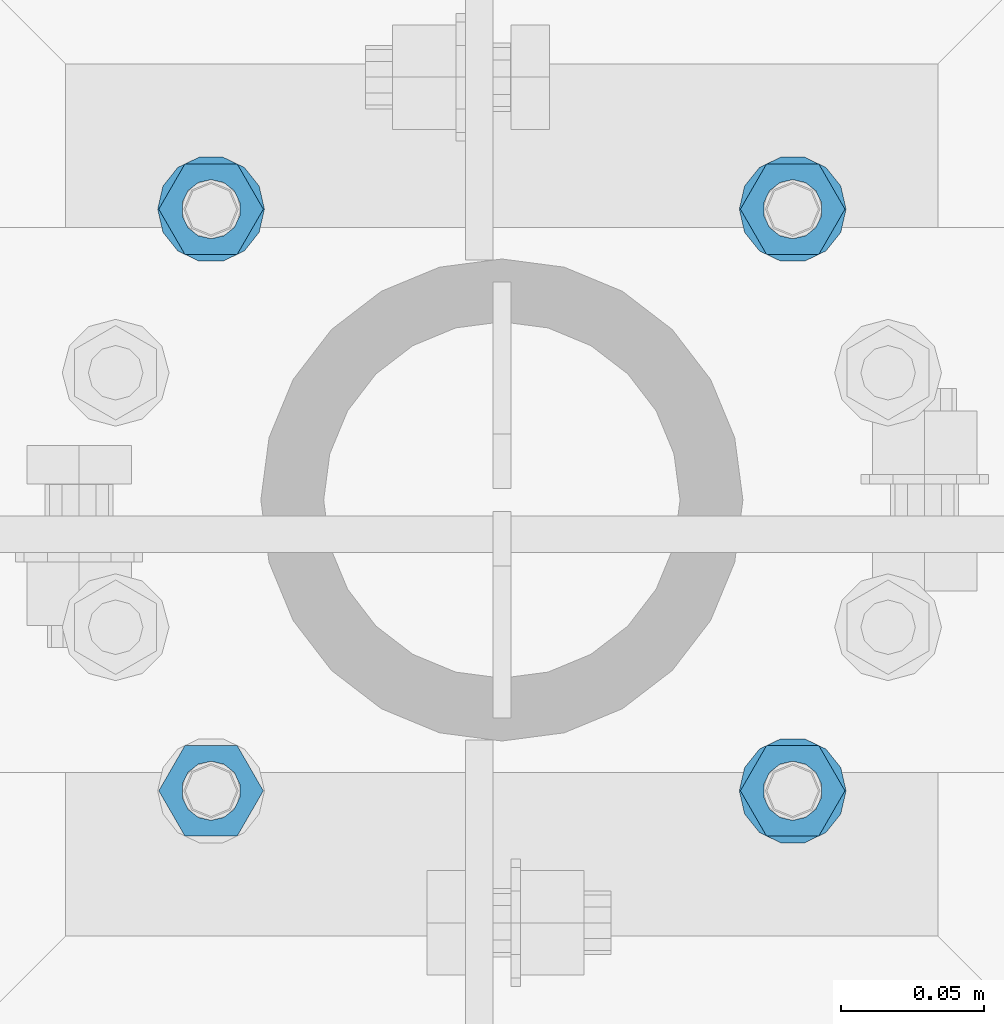
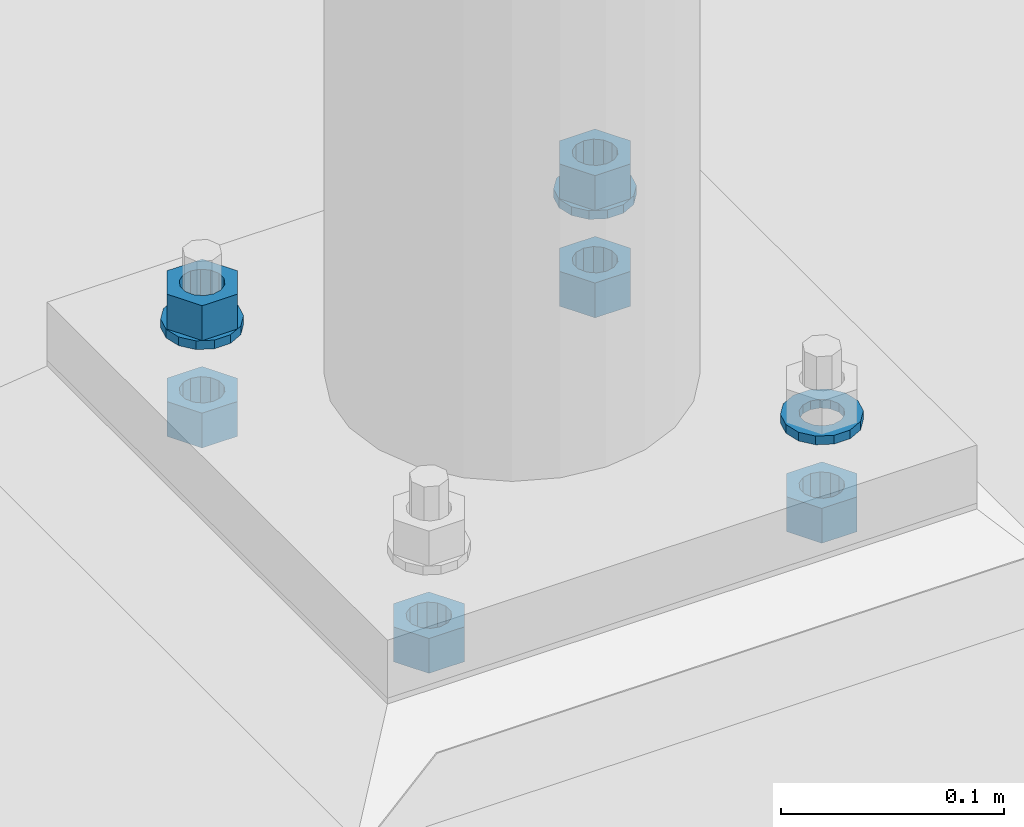
# One storey, part 572 of 975: 9 beams.
"""IFC2X3 building model written with IfcOpenShell, lengths in millimetres."""

from ifc_helpers import new_model, si_unit, frame, origin_with_axes, place, context, subcontext, project, spatial, faceted_brep, material, type_object, element, save


model = new_model("IFC2X3")

# Units and contexts
model_context = context("Model", 3, precision=1e-05, world=origin_with_axes())
body_context = subcontext(model_context, "Body", "Model", "MODEL_VIEW")
ifc_project = project(units=[si_unit("LENGTHUNIT", "METRE", prefix="MILLI"), si_unit("AREAUNIT", "SQUARE_METRE"), si_unit("VOLUMEUNIT", "CUBIC_METRE"), si_unit("MASSUNIT", "GRAM", prefix="KILO"), si_unit("TIMEUNIT", "SECOND"), si_unit("PLANEANGLEUNIT", "RADIAN"), si_unit("SOLIDANGLEUNIT", "STERADIAN"), si_unit("THERMODYNAMICTEMPERATUREUNIT", "DEGREE_CELSIUS"), si_unit("LUMINOUSINTENSITYUNIT", "LUMEN")], contexts=[model_context])

# Site, building, storey
site_placement = place(None, origin_with_axes())
site = spatial("IfcSite", under=ifc_project, at=site_placement, CompositionType="ELEMENT")
building_placement = place(site_placement, origin_with_axes())
building = spatial("IfcBuilding", under=site, at=building_placement, Name="Undefined", CompositionType="ELEMENT")
storey_placement = place(building_placement, origin_with_axes())
storey = spatial("IfcBuildingStorey", under=building, at=storey_placement, Name="Undefined", CompositionType="ELEMENT", Elevation=0.0)

# Beams
ifc_material = material(Name="STEEL/A36")
beam_type_1 = type_object("IfcBeamType", Name="3/4_WASHER", PredefinedType="NOTDEFINED")
beam_1_placement = place(storey_placement, frame((13588.9999984741, 5718.17500305176, -227.0125), z_axis=(0.0, 1.0, 0.0), x_axis=(0.0, 0.0, -1.0)))
element("IfcBeam", 1, at=beam_1_placement, inside=storey, type_object=beam_type_1, material=ifc_material, Name="WASHER", ObjectType="3/4_WASHER", context=body_context, shape_type="Brep", body=[
    faceted_brep([(0.0, -18.6499996185303, 0.0), (0.0, -16.8030690426876, -8.09193156902904), (4.76250000000073, -16.8030690426876, -8.09193156902904), (4.76250000000073, -18.6499996185303, 0.0), (0.0, -11.6280845668225, -14.5811568497838), (4.76250000000073, -11.6280845668225, -14.5811568497838), (0.0, -4.15001533340001, -18.1824051902857), (4.76250000000073, -4.15001533340001, -18.1824051902857), (0.0, 4.15001533340001, -18.1824051902857), (4.76250000000073, 4.15001533340001, -18.1824051902857), (0.0, 11.6280845668234, -14.5811568497838), (4.76250000000073, 11.6280845668234, -14.5811568497838), (0.0, 16.8030690426876, -8.09193156902904), (4.76250000000073, 16.8030690426876, -8.09193156902904), (0.0, 18.6499996185303, 0.0), (4.76250000000073, 18.6499996185303, 0.0), (0.0, 16.8030690426876, 8.09193156902904), (4.76250000000073, 16.8030690426876, 8.09193156902904), (0.0, 11.6280845668225, 14.5811568497838), (4.76250000000073, 11.6280845668225, 14.5811568497838), (0.0, 4.15001533340001, 18.1824051902857), (4.76250000000073, 4.15001533340001, 18.1824051902857), (0.0, -4.15001533340001, 18.1824051902857), (4.76250000000073, -4.15001533340001, 18.1824051902857), (0.0, -11.6280845668234, 14.5811568497838), (4.76250000000073, -11.6280845668234, 14.5811568497838), (0.0, -16.8030690426876, 8.09193156902904), (4.76250000000073, -16.8030690426876, 8.09193156902904), (0.0, 0.0, 10.3199996948242), (0.0, 4.47768005528269, 9.29799844179911), (4.76250000000073, 4.47768005528269, 9.29799844179911), (4.76250000000073, 0.0, 10.3199996948242), (0.0, 8.06850066047446, 6.43441456490817), (4.76250000000073, 8.06850066047446, 6.43441456490817), (0.0, 10.0612557561917, 2.29641597052117), (4.76250000000073, 10.0612557561917, 2.29641597052117), (0.0, 10.0612557561917, -2.29641597052117), (4.76250000000073, 10.0612557561917, -2.29641597052117), (0.0, 8.06850066047446, -6.43441456490814), (4.76250000000073, 8.06850066047446, -6.43441456490814), (0.0, 4.47768005528269, -9.29799844179908), (4.76250000000073, 4.47768005528269, -9.29799844179908), (0.0, 0.0, -10.3199996948242), (4.76250000000073, 0.0, -10.3199996948242), (0.0, -4.47768005528269, -9.29799844179911), (4.76250000000073, -4.47768005528269, -9.29799844179911), (0.0, -8.06850066047446, -6.43441456490817), (4.76250000000073, -8.06850066047446, -6.43441456490817), (0.0, -10.0612557561917, -2.29641597052117), (4.76250000000073, -10.0612557561917, -2.29641597052117), (0.0, -10.0612557561917, 2.29641597052117), (4.76250000000073, -10.0612557561917, 2.29641597052117), (0.0, -8.06850066047446, 6.43441456490814), (4.76250000000073, -8.06850066047446, 6.43441456490814), (0.0, -4.47768005528269, 9.29799844179908), (4.76250000000073, -4.47768005528269, 9.29799844179908)], [[[0, 1, 2, 3]], [[1, 4, 5, 2]], [[4, 6, 7, 5]], [[6, 8, 9, 7]], [[8, 10, 11, 9]], [[10, 12, 13, 11]], [[12, 14, 15, 13]], [[14, 16, 17, 15]], [[16, 18, 19, 17]], [[18, 20, 21, 19]], [[20, 22, 23, 21]], [[22, 24, 25, 23]], [[24, 26, 27, 25]], [[26, 0, 3, 27]], [[28, 29, 30, 31]], [[29, 32, 33, 30]], [[32, 34, 35, 33]], [[34, 36, 37, 35]], [[36, 38, 39, 37]], [[38, 40, 41, 39]], [[40, 42, 43, 41]], [[42, 44, 45, 43]], [[44, 46, 47, 45]], [[46, 48, 49, 47]], [[48, 50, 51, 49]], [[50, 52, 53, 51]], [[52, 54, 55, 53]], [[54, 28, 31, 55]], [[5, 7, 9, 11, 13, 15, 17, 19, 21, 23, 25, 27, 3, 2], [33, 35, 37, 39, 41, 43, 45, 47, 49, 51, 53, 55, 31, 30]], [[26, 24, 22, 20, 18, 16, 14, 12, 10, 8, 6, 4, 1, 0], [54, 52, 50, 48, 46, 44, 42, 40, 38, 36, 34, 32, 29, 28]]]),
])
beam_2_placement = place(storey_placement, frame((13385.8000015259, 5921.375, -227.0125), z_axis=(0.0, -1.0, 0.0), x_axis=(0.0, 0.0, -1.0)))
element("IfcBeam", 2, at=beam_2_placement, inside=storey, type_object=beam_type_1, material=ifc_material, Name="WASHER", ObjectType="3/4_WASHER", context=body_context, shape_type="Brep", body=[
    faceted_brep([(0.0, -18.6499996185303, 0.0), (0.0, -16.8030690426876, -8.09193156902904), (4.76250000000073, -16.8030690426876, -8.09193156902904), (4.76250000000073, -18.6499996185303, 0.0), (0.0, -11.6280845668225, -14.5811568497838), (4.76250000000073, -11.6280845668225, -14.5811568497838), (0.0, -4.15001533340001, -18.1824051902857), (4.76250000000073, -4.15001533340001, -18.1824051902857), (0.0, 4.15001533340001, -18.1824051902857), (4.76250000000073, 4.15001533340001, -18.1824051902857), (0.0, 11.6280845668234, -14.5811568497838), (4.76250000000073, 11.6280845668234, -14.5811568497838), (0.0, 16.8030690426876, -8.09193156902904), (4.76250000000073, 16.8030690426876, -8.09193156902904), (0.0, 18.6499996185303, 0.0), (4.76250000000073, 18.6499996185303, 0.0), (0.0, 16.8030690426876, 8.09193156902904), (4.76250000000073, 16.8030690426876, 8.09193156902904), (0.0, 11.6280845668225, 14.5811568497838), (4.76250000000073, 11.6280845668225, 14.5811568497838), (0.0, 4.15001533340001, 18.1824051902857), (4.76250000000073, 4.15001533340001, 18.1824051902857), (0.0, -4.15001533340001, 18.1824051902857), (4.76250000000073, -4.15001533340001, 18.1824051902857), (0.0, -11.6280845668234, 14.5811568497838), (4.76250000000073, -11.6280845668234, 14.5811568497838), (0.0, -16.8030690426876, 8.09193156902904), (4.76250000000073, -16.8030690426876, 8.09193156902904), (0.0, 0.0, 10.3199996948242), (0.0, 4.47768005528269, 9.29799844179911), (4.76250000000073, 4.47768005528269, 9.29799844179911), (4.76250000000073, 0.0, 10.3199996948242), (0.0, 8.06850066047446, 6.43441456490817), (4.76250000000073, 8.06850066047446, 6.43441456490817), (0.0, 10.0612557561917, 2.29641597052117), (4.76250000000073, 10.0612557561917, 2.29641597052117), (0.0, 10.0612557561917, -2.29641597052117), (4.76250000000073, 10.0612557561917, -2.29641597052117), (0.0, 8.06850066047446, -6.43441456490814), (4.76250000000073, 8.06850066047446, -6.43441456490814), (0.0, 4.47768005528269, -9.29799844179908), (4.76250000000073, 4.47768005528269, -9.29799844179908), (0.0, 0.0, -10.3199996948242), (4.76250000000073, 0.0, -10.3199996948242), (0.0, -4.47768005528269, -9.29799844179911), (4.76250000000073, -4.47768005528269, -9.29799844179911), (0.0, -8.06850066047446, -6.43441456490817), (4.76250000000073, -8.06850066047446, -6.43441456490817), (0.0, -10.0612557561917, -2.29641597052117), (4.76250000000073, -10.0612557561917, -2.29641597052117), (0.0, -10.0612557561917, 2.29641597052117), (4.76250000000073, -10.0612557561917, 2.29641597052117), (0.0, -8.06850066047446, 6.43441456490814), (4.76250000000073, -8.06850066047446, 6.43441456490814), (0.0, -4.47768005528269, 9.29799844179908), (4.76250000000073, -4.47768005528269, 9.29799844179908)], [[[0, 1, 2, 3]], [[1, 4, 5, 2]], [[4, 6, 7, 5]], [[6, 8, 9, 7]], [[8, 10, 11, 9]], [[10, 12, 13, 11]], [[12, 14, 15, 13]], [[14, 16, 17, 15]], [[16, 18, 19, 17]], [[18, 20, 21, 19]], [[20, 22, 23, 21]], [[22, 24, 25, 23]], [[24, 26, 27, 25]], [[26, 0, 3, 27]], [[28, 29, 30, 31]], [[29, 32, 33, 30]], [[32, 34, 35, 33]], [[34, 36, 37, 35]], [[36, 38, 39, 37]], [[38, 40, 41, 39]], [[40, 42, 43, 41]], [[42, 44, 45, 43]], [[44, 46, 47, 45]], [[46, 48, 49, 47]], [[48, 50, 51, 49]], [[50, 52, 53, 51]], [[52, 54, 55, 53]], [[54, 28, 31, 55]], [[5, 7, 9, 11, 13, 15, 17, 19, 21, 23, 25, 27, 3, 2], [33, 35, 37, 39, 41, 43, 45, 47, 49, 51, 53, 55, 31, 30]], [[26, 24, 22, 20, 18, 16, 14, 12, 10, 8, 6, 4, 1, 0], [54, 52, 50, 48, 46, 44, 42, 40, 38, 36, 34, 32, 29, 28]]]),
])
beam_3_placement = place(storey_placement, frame((13588.9999984741, 5921.375, -227.0125), z_axis=(0.0, 1.0, 0.0), x_axis=(0.0, 0.0, -1.0)))
element("IfcBeam", 3, at=beam_3_placement, inside=storey, type_object=beam_type_1, material=ifc_material, Name="WASHER", ObjectType="3/4_WASHER", context=body_context, shape_type="Brep", body=[
    faceted_brep([(0.0, -18.6499996185303, 0.0), (0.0, -16.8030690426876, -8.09193156902904), (4.76250000000073, -16.8030690426876, -8.09193156902904), (4.76250000000073, -18.6499996185303, 0.0), (0.0, -11.6280845668225, -14.5811568497838), (4.76250000000073, -11.6280845668225, -14.5811568497838), (0.0, -4.15001533340001, -18.1824051902857), (4.76250000000073, -4.15001533340001, -18.1824051902857), (0.0, 4.15001533340001, -18.1824051902857), (4.76250000000073, 4.15001533340001, -18.1824051902857), (0.0, 11.6280845668234, -14.5811568497838), (4.76250000000073, 11.6280845668234, -14.5811568497838), (0.0, 16.8030690426876, -8.09193156902904), (4.76250000000073, 16.8030690426876, -8.09193156902904), (0.0, 18.6499996185303, 0.0), (4.76250000000073, 18.6499996185303, 0.0), (0.0, 16.8030690426876, 8.09193156902904), (4.76250000000073, 16.8030690426876, 8.09193156902904), (0.0, 11.6280845668225, 14.5811568497838), (4.76250000000073, 11.6280845668225, 14.5811568497838), (0.0, 4.15001533340001, 18.1824051902857), (4.76250000000073, 4.15001533340001, 18.1824051902857), (0.0, -4.15001533340001, 18.1824051902857), (4.76250000000073, -4.15001533340001, 18.1824051902857), (0.0, -11.6280845668234, 14.5811568497838), (4.76250000000073, -11.6280845668234, 14.5811568497838), (0.0, -16.8030690426876, 8.09193156902904), (4.76250000000073, -16.8030690426876, 8.09193156902904), (0.0, 0.0, 10.3199996948242), (0.0, 4.47768005528269, 9.29799844179911), (4.76250000000073, 4.47768005528269, 9.29799844179911), (4.76250000000073, 0.0, 10.3199996948242), (0.0, 8.06850066047446, 6.43441456490817), (4.76250000000073, 8.06850066047446, 6.43441456490817), (0.0, 10.0612557561917, 2.29641597052117), (4.76250000000073, 10.0612557561917, 2.29641597052117), (0.0, 10.0612557561917, -2.29641597052117), (4.76250000000073, 10.0612557561917, -2.29641597052117), (0.0, 8.06850066047446, -6.43441456490814), (4.76250000000073, 8.06850066047446, -6.43441456490814), (0.0, 4.47768005528269, -9.29799844179908), (4.76250000000073, 4.47768005528269, -9.29799844179908), (0.0, 0.0, -10.3199996948242), (4.76250000000073, 0.0, -10.3199996948242), (0.0, -4.47768005528269, -9.29799844179911), (4.76250000000073, -4.47768005528269, -9.29799844179911), (0.0, -8.06850066047446, -6.43441456490817), (4.76250000000073, -8.06850066047446, -6.43441456490817), (0.0, -10.0612557561917, -2.29641597052117), (4.76250000000073, -10.0612557561917, -2.29641597052117), (0.0, -10.0612557561917, 2.29641597052117), (4.76250000000073, -10.0612557561917, 2.29641597052117), (0.0, -8.06850066047446, 6.43441456490814), (4.76250000000073, -8.06850066047446, 6.43441456490814), (0.0, -4.47768005528269, 9.29799844179908), (4.76250000000073, -4.47768005528269, 9.29799844179908)], [[[0, 1, 2, 3]], [[1, 4, 5, 2]], [[4, 6, 7, 5]], [[6, 8, 9, 7]], [[8, 10, 11, 9]], [[10, 12, 13, 11]], [[12, 14, 15, 13]], [[14, 16, 17, 15]], [[16, 18, 19, 17]], [[18, 20, 21, 19]], [[20, 22, 23, 21]], [[22, 24, 25, 23]], [[24, 26, 27, 25]], [[26, 0, 3, 27]], [[28, 29, 30, 31]], [[29, 32, 33, 30]], [[32, 34, 35, 33]], [[34, 36, 37, 35]], [[36, 38, 39, 37]], [[38, 40, 41, 39]], [[40, 42, 43, 41]], [[42, 44, 45, 43]], [[44, 46, 47, 45]], [[46, 48, 49, 47]], [[48, 50, 51, 49]], [[50, 52, 53, 51]], [[52, 54, 55, 53]], [[54, 28, 31, 55]], [[5, 7, 9, 11, 13, 15, 17, 19, 21, 23, 25, 27, 3, 2], [33, 35, 37, 39, 41, 43, 45, 47, 49, 51, 53, 55, 31, 30]], [[26, 24, 22, 20, 18, 16, 14, 12, 10, 8, 6, 4, 1, 0], [54, 52, 50, 48, 46, 44, 42, 40, 38, 36, 34, 32, 29, 28]]]),
])
beam_type_2 = type_object("IfcBeamType", Name="3/4_HEAVY_HEX_NUT", PredefinedType="NOTDEFINED")
beam_4_placement = place(storey_placement, frame((13385.8000015259, 5921.375, -207.962500000001), z_axis=(0.0, -1.0, 0.0), x_axis=(0.0, 0.0, -1.0)))
element("IfcBeam", 4, at=beam_4_placement, inside=storey, type_object=beam_type_2, material=ifc_material, Name="NUT", ObjectType="3/4_HEAVY_HEX_NUT", context=body_context, shape_type="Brep", body=[
    faceted_brep([(0.0, -18.2600002288818, 0.0), (0.0, -9.13000011444092, -15.8100004196167), (19.0499999999993, -9.13000011444092, -15.8100004196167), (19.0499999999993, -18.2600002288818, 0.0), (0.0, 9.13000011444092, -15.8100004196167), (19.0499999999993, 9.13000011444092, -15.8100004196167), (0.0, 18.2600002288818, 0.0), (19.0499999999993, 18.2600002288818, 0.0), (0.0, 9.13000011444092, 15.8100004196167), (19.0499999999993, 9.13000011444092, 15.8100004196167), (0.0, -9.13000011444092, 15.8100004196167), (19.0499999999993, -9.13000011444092, 15.8100004196167), (0.0, 0.0, 10.3199996948242), (0.0, 4.47768005528269, 9.29799844179911), (19.0499999999993, 4.47768005528269, 9.29799844179911), (19.0499999999993, 0.0, 10.3199996948242), (0.0, 8.06850066047446, 6.43441456490817), (19.0499999999993, 8.06850066047446, 6.43441456490817), (0.0, 10.0612557561917, 2.29641597052117), (19.0499999999993, 10.0612557561917, 2.29641597052117), (0.0, 10.0612557561917, -2.29641597052117), (19.0499999999993, 10.0612557561917, -2.29641597052117), (0.0, 8.06850066047446, -6.43441456490814), (19.0499999999993, 8.06850066047446, -6.43441456490814), (0.0, 4.47768005528269, -9.29799844179908), (19.0499999999993, 4.47768005528269, -9.29799844179908), (0.0, 0.0, -10.3199996948242), (19.0499999999993, 0.0, -10.3199996948242), (0.0, -4.47768005528269, -9.29799844179911), (19.0499999999993, -4.47768005528269, -9.29799844179911), (0.0, -8.06850066047446, -6.43441456490817), (19.0499999999993, -8.06850066047446, -6.43441456490817), (0.0, -10.0612557561917, -2.29641597052117), (19.0499999999993, -10.0612557561917, -2.29641597052117), (0.0, -10.0612557561917, 2.29641597052117), (19.0499999999993, -10.0612557561917, 2.29641597052117), (0.0, -8.06850066047446, 6.43441456490814), (19.0499999999993, -8.06850066047446, 6.43441456490814), (0.0, -4.47768005528269, 9.29799844179908), (19.0499999999993, -4.47768005528269, 9.29799844179908)], [[[0, 1, 2, 3]], [[1, 4, 5, 2]], [[4, 6, 7, 5]], [[6, 8, 9, 7]], [[8, 10, 11, 9]], [[10, 0, 3, 11]], [[12, 13, 14, 15]], [[13, 16, 17, 14]], [[16, 18, 19, 17]], [[18, 20, 21, 19]], [[20, 22, 23, 21]], [[22, 24, 25, 23]], [[24, 26, 27, 25]], [[26, 28, 29, 27]], [[28, 30, 31, 29]], [[30, 32, 33, 31]], [[32, 34, 35, 33]], [[34, 36, 37, 35]], [[36, 38, 39, 37]], [[38, 12, 15, 39]], [[5, 7, 9, 11, 3, 2], [17, 19, 21, 23, 25, 27, 29, 31, 33, 35, 37, 39, 15, 14]], [[10, 8, 6, 4, 1, 0], [38, 36, 34, 32, 30, 28, 26, 24, 22, 20, 18, 16, 13, 12]]]),
])
beam_5_placement = place(storey_placement, frame((13588.9999984741, 5921.375, -207.962500000001), z_axis=(0.0, 1.0, 0.0), x_axis=(0.0, 0.0, -1.0)))
element("IfcBeam", 5, at=beam_5_placement, inside=storey, type_object=beam_type_2, material=ifc_material, Name="NUT", ObjectType="3/4_HEAVY_HEX_NUT", context=body_context, shape_type="Brep", body=[
    faceted_brep([(0.0, -18.2600002288818, 0.0), (0.0, -9.13000011444092, -15.8100004196167), (19.0499999999993, -9.13000011444092, -15.8100004196167), (19.0499999999993, -18.2600002288818, 0.0), (0.0, 9.13000011444092, -15.8100004196167), (19.0499999999993, 9.13000011444092, -15.8100004196167), (0.0, 18.2600002288818, 0.0), (19.0499999999993, 18.2600002288818, 0.0), (0.0, 9.13000011444092, 15.8100004196167), (19.0499999999993, 9.13000011444092, 15.8100004196167), (0.0, -9.13000011444092, 15.8100004196167), (19.0499999999993, -9.13000011444092, 15.8100004196167), (0.0, 0.0, 10.3199996948242), (0.0, 4.47768005528269, 9.29799844179911), (19.0499999999993, 4.47768005528269, 9.29799844179911), (19.0499999999993, 0.0, 10.3199996948242), (0.0, 8.06850066047446, 6.43441456490817), (19.0499999999993, 8.06850066047446, 6.43441456490817), (0.0, 10.0612557561917, 2.29641597052117), (19.0499999999993, 10.0612557561917, 2.29641597052117), (0.0, 10.0612557561917, -2.29641597052117), (19.0499999999993, 10.0612557561917, -2.29641597052117), (0.0, 8.06850066047446, -6.43441456490814), (19.0499999999993, 8.06850066047446, -6.43441456490814), (0.0, 4.47768005528269, -9.29799844179908), (19.0499999999993, 4.47768005528269, -9.29799844179908), (0.0, 0.0, -10.3199996948242), (19.0499999999993, 0.0, -10.3199996948242), (0.0, -4.47768005528269, -9.29799844179911), (19.0499999999993, -4.47768005528269, -9.29799844179911), (0.0, -8.06850066047446, -6.43441456490817), (19.0499999999993, -8.06850066047446, -6.43441456490817), (0.0, -10.0612557561917, -2.29641597052117), (19.0499999999993, -10.0612557561917, -2.29641597052117), (0.0, -10.0612557561917, 2.29641597052117), (19.0499999999993, -10.0612557561917, 2.29641597052117), (0.0, -8.06850066047446, 6.43441456490814), (19.0499999999993, -8.06850066047446, 6.43441456490814), (0.0, -4.47768005528269, 9.29799844179908), (19.0499999999993, -4.47768005528269, 9.29799844179908)], [[[0, 1, 2, 3]], [[1, 4, 5, 2]], [[4, 6, 7, 5]], [[6, 8, 9, 7]], [[8, 10, 11, 9]], [[10, 0, 3, 11]], [[12, 13, 14, 15]], [[13, 16, 17, 14]], [[16, 18, 19, 17]], [[18, 20, 21, 19]], [[20, 22, 23, 21]], [[22, 24, 25, 23]], [[24, 26, 27, 25]], [[26, 28, 29, 27]], [[28, 30, 31, 29]], [[30, 32, 33, 31]], [[32, 34, 35, 33]], [[34, 36, 37, 35]], [[36, 38, 39, 37]], [[38, 12, 15, 39]], [[5, 7, 9, 11, 3, 2], [17, 19, 21, 23, 25, 27, 29, 31, 33, 35, 37, 39, 15, 14]], [[10, 8, 6, 4, 1, 0], [38, 36, 34, 32, 30, 28, 26, 24, 22, 20, 18, 16, 13, 12]]]),
])
beam_6_placement = place(storey_placement, frame((13385.8000015259, 5718.17500305176, -266.7), z_axis=(0.0, -1.0, 0.0), x_axis=(0.0, 0.0, -1.0)))
element("IfcBeam", 6, at=beam_6_placement, inside=storey, type_object=beam_type_2, material=ifc_material, Name="NUT", ObjectType="3/4_HEAVY_HEX_NUT", context=body_context, shape_type="Brep", body=[
    faceted_brep([(0.0, -18.2600002288818, 0.0), (0.0, -9.13000011444092, -15.8100004196167), (19.0499999999993, -9.13000011444092, -15.8100004196167), (19.0499999999993, -18.2600002288818, 0.0), (0.0, 9.13000011444092, -15.8100004196167), (19.0499999999993, 9.13000011444092, -15.8100004196167), (0.0, 18.2600002288818, 0.0), (19.0499999999993, 18.2600002288818, 0.0), (0.0, 9.13000011444092, 15.8100004196167), (19.0499999999993, 9.13000011444092, 15.8100004196167), (0.0, -9.13000011444092, 15.8100004196167), (19.0499999999993, -9.13000011444092, 15.8100004196167), (0.0, 0.0, 10.3199996948242), (0.0, 4.47768005528269, 9.29799844179911), (19.0499999999993, 4.47768005528269, 9.29799844179911), (19.0499999999993, 0.0, 10.3199996948242), (0.0, 8.06850066047446, 6.43441456490817), (19.0499999999993, 8.06850066047446, 6.43441456490817), (0.0, 10.0612557561917, 2.29641597052117), (19.0499999999993, 10.0612557561917, 2.29641597052117), (0.0, 10.0612557561917, -2.29641597052117), (19.0499999999993, 10.0612557561917, -2.29641597052117), (0.0, 8.06850066047446, -6.43441456490814), (19.0499999999993, 8.06850066047446, -6.43441456490814), (0.0, 4.47768005528269, -9.29799844179908), (19.0499999999993, 4.47768005528269, -9.29799844179908), (0.0, 0.0, -10.3199996948242), (19.0499999999993, 0.0, -10.3199996948242), (0.0, -4.47768005528269, -9.29799844179911), (19.0499999999993, -4.47768005528269, -9.29799844179911), (0.0, -8.06850066047446, -6.43441456490817), (19.0499999999993, -8.06850066047446, -6.43441456490817), (0.0, -10.0612557561917, -2.29641597052117), (19.0499999999993, -10.0612557561917, -2.29641597052117), (0.0, -10.0612557561917, 2.29641597052117), (19.0499999999993, -10.0612557561917, 2.29641597052117), (0.0, -8.06850066047446, 6.43441456490814), (19.0499999999993, -8.06850066047446, 6.43441456490814), (0.0, -4.47768005528269, 9.29799844179908), (19.0499999999993, -4.47768005528269, 9.29799844179908)], [[[0, 1, 2, 3]], [[1, 4, 5, 2]], [[4, 6, 7, 5]], [[6, 8, 9, 7]], [[8, 10, 11, 9]], [[10, 0, 3, 11]], [[12, 13, 14, 15]], [[13, 16, 17, 14]], [[16, 18, 19, 17]], [[18, 20, 21, 19]], [[20, 22, 23, 21]], [[22, 24, 25, 23]], [[24, 26, 27, 25]], [[26, 28, 29, 27]], [[28, 30, 31, 29]], [[30, 32, 33, 31]], [[32, 34, 35, 33]], [[34, 36, 37, 35]], [[36, 38, 39, 37]], [[38, 12, 15, 39]], [[5, 7, 9, 11, 3, 2], [17, 19, 21, 23, 25, 27, 29, 31, 33, 35, 37, 39, 15, 14]], [[10, 8, 6, 4, 1, 0], [38, 36, 34, 32, 30, 28, 26, 24, 22, 20, 18, 16, 13, 12]]]),
])
beam_7_placement = place(storey_placement, frame((13588.9999984741, 5718.17500305176, -266.7), z_axis=(0.0, 1.0, 0.0), x_axis=(0.0, 0.0, -1.0)))
element("IfcBeam", 7, at=beam_7_placement, inside=storey, type_object=beam_type_2, material=ifc_material, Name="NUT", ObjectType="3/4_HEAVY_HEX_NUT", context=body_context, shape_type="Brep", body=[
    faceted_brep([(0.0, -18.2600002288818, 0.0), (0.0, -9.13000011444092, -15.8100004196167), (19.0499999999993, -9.13000011444092, -15.8100004196167), (19.0499999999993, -18.2600002288818, 0.0), (0.0, 9.13000011444092, -15.8100004196167), (19.0499999999993, 9.13000011444092, -15.8100004196167), (0.0, 18.2600002288818, 0.0), (19.0499999999993, 18.2600002288818, 0.0), (0.0, 9.13000011444092, 15.8100004196167), (19.0499999999993, 9.13000011444092, 15.8100004196167), (0.0, -9.13000011444092, 15.8100004196167), (19.0499999999993, -9.13000011444092, 15.8100004196167), (0.0, 0.0, 10.3199996948242), (0.0, 4.47768005528269, 9.29799844179911), (19.0499999999993, 4.47768005528269, 9.29799844179911), (19.0499999999993, 0.0, 10.3199996948242), (0.0, 8.06850066047446, 6.43441456490817), (19.0499999999993, 8.06850066047446, 6.43441456490817), (0.0, 10.0612557561917, 2.29641597052117), (19.0499999999993, 10.0612557561917, 2.29641597052117), (0.0, 10.0612557561917, -2.29641597052117), (19.0499999999993, 10.0612557561917, -2.29641597052117), (0.0, 8.06850066047446, -6.43441456490814), (19.0499999999993, 8.06850066047446, -6.43441456490814), (0.0, 4.47768005528269, -9.29799844179908), (19.0499999999993, 4.47768005528269, -9.29799844179908), (0.0, 0.0, -10.3199996948242), (19.0499999999993, 0.0, -10.3199996948242), (0.0, -4.47768005528269, -9.29799844179911), (19.0499999999993, -4.47768005528269, -9.29799844179911), (0.0, -8.06850066047446, -6.43441456490817), (19.0499999999993, -8.06850066047446, -6.43441456490817), (0.0, -10.0612557561917, -2.29641597052117), (19.0499999999993, -10.0612557561917, -2.29641597052117), (0.0, -10.0612557561917, 2.29641597052117), (19.0499999999993, -10.0612557561917, 2.29641597052117), (0.0, -8.06850066047446, 6.43441456490814), (19.0499999999993, -8.06850066047446, 6.43441456490814), (0.0, -4.47768005528269, 9.29799844179908), (19.0499999999993, -4.47768005528269, 9.29799844179908)], [[[0, 1, 2, 3]], [[1, 4, 5, 2]], [[4, 6, 7, 5]], [[6, 8, 9, 7]], [[8, 10, 11, 9]], [[10, 0, 3, 11]], [[12, 13, 14, 15]], [[13, 16, 17, 14]], [[16, 18, 19, 17]], [[18, 20, 21, 19]], [[20, 22, 23, 21]], [[22, 24, 25, 23]], [[24, 26, 27, 25]], [[26, 28, 29, 27]], [[28, 30, 31, 29]], [[30, 32, 33, 31]], [[32, 34, 35, 33]], [[34, 36, 37, 35]], [[36, 38, 39, 37]], [[38, 12, 15, 39]], [[5, 7, 9, 11, 3, 2], [17, 19, 21, 23, 25, 27, 29, 31, 33, 35, 37, 39, 15, 14]], [[10, 8, 6, 4, 1, 0], [38, 36, 34, 32, 30, 28, 26, 24, 22, 20, 18, 16, 13, 12]]]),
])
beam_8_placement = place(storey_placement, frame((13385.8000015259, 5921.375, -266.7), z_axis=(0.0, -1.0, 0.0), x_axis=(0.0, 0.0, -1.0)))
element("IfcBeam", 8, at=beam_8_placement, inside=storey, type_object=beam_type_2, material=ifc_material, Name="NUT", ObjectType="3/4_HEAVY_HEX_NUT", context=body_context, shape_type="Brep", body=[
    faceted_brep([(0.0, -18.2600002288818, 0.0), (0.0, -9.13000011444092, -15.8100004196167), (19.0499999999993, -9.13000011444092, -15.8100004196167), (19.0499999999993, -18.2600002288818, 0.0), (0.0, 9.13000011444092, -15.8100004196167), (19.0499999999993, 9.13000011444092, -15.8100004196167), (0.0, 18.2600002288818, 0.0), (19.0499999999993, 18.2600002288818, 0.0), (0.0, 9.13000011444092, 15.8100004196167), (19.0499999999993, 9.13000011444092, 15.8100004196167), (0.0, -9.13000011444092, 15.8100004196167), (19.0499999999993, -9.13000011444092, 15.8100004196167), (0.0, 0.0, 10.3199996948242), (0.0, 4.47768005528269, 9.29799844179911), (19.0499999999993, 4.47768005528269, 9.29799844179911), (19.0499999999993, 0.0, 10.3199996948242), (0.0, 8.06850066047446, 6.43441456490817), (19.0499999999993, 8.06850066047446, 6.43441456490817), (0.0, 10.0612557561917, 2.29641597052117), (19.0499999999993, 10.0612557561917, 2.29641597052117), (0.0, 10.0612557561917, -2.29641597052117), (19.0499999999993, 10.0612557561917, -2.29641597052117), (0.0, 8.06850066047446, -6.43441456490814), (19.0499999999993, 8.06850066047446, -6.43441456490814), (0.0, 4.47768005528269, -9.29799844179908), (19.0499999999993, 4.47768005528269, -9.29799844179908), (0.0, 0.0, -10.3199996948242), (19.0499999999993, 0.0, -10.3199996948242), (0.0, -4.47768005528269, -9.29799844179911), (19.0499999999993, -4.47768005528269, -9.29799844179911), (0.0, -8.06850066047446, -6.43441456490817), (19.0499999999993, -8.06850066047446, -6.43441456490817), (0.0, -10.0612557561917, -2.29641597052117), (19.0499999999993, -10.0612557561917, -2.29641597052117), (0.0, -10.0612557561917, 2.29641597052117), (19.0499999999993, -10.0612557561917, 2.29641597052117), (0.0, -8.06850066047446, 6.43441456490814), (19.0499999999993, -8.06850066047446, 6.43441456490814), (0.0, -4.47768005528269, 9.29799844179908), (19.0499999999993, -4.47768005528269, 9.29799844179908)], [[[0, 1, 2, 3]], [[1, 4, 5, 2]], [[4, 6, 7, 5]], [[6, 8, 9, 7]], [[8, 10, 11, 9]], [[10, 0, 3, 11]], [[12, 13, 14, 15]], [[13, 16, 17, 14]], [[16, 18, 19, 17]], [[18, 20, 21, 19]], [[20, 22, 23, 21]], [[22, 24, 25, 23]], [[24, 26, 27, 25]], [[26, 28, 29, 27]], [[28, 30, 31, 29]], [[30, 32, 33, 31]], [[32, 34, 35, 33]], [[34, 36, 37, 35]], [[36, 38, 39, 37]], [[38, 12, 15, 39]], [[5, 7, 9, 11, 3, 2], [17, 19, 21, 23, 25, 27, 29, 31, 33, 35, 37, 39, 15, 14]], [[10, 8, 6, 4, 1, 0], [38, 36, 34, 32, 30, 28, 26, 24, 22, 20, 18, 16, 13, 12]]]),
])
beam_9_placement = place(storey_placement, frame((13588.9999984741, 5921.375, -266.7), z_axis=(0.0, 1.0, 0.0), x_axis=(0.0, 0.0, -1.0)))
element("IfcBeam", 9, at=beam_9_placement, inside=storey, type_object=beam_type_2, material=ifc_material, Name="NUT", ObjectType="3/4_HEAVY_HEX_NUT", context=body_context, shape_type="Brep", body=[
    faceted_brep([(0.0, -18.2600002288818, 0.0), (0.0, -9.13000011444092, -15.8100004196167), (19.0499999999993, -9.13000011444092, -15.8100004196167), (19.0499999999993, -18.2600002288818, 0.0), (0.0, 9.13000011444092, -15.8100004196167), (19.0499999999993, 9.13000011444092, -15.8100004196167), (0.0, 18.2600002288818, 0.0), (19.0499999999993, 18.2600002288818, 0.0), (0.0, 9.13000011444092, 15.8100004196167), (19.0499999999993, 9.13000011444092, 15.8100004196167), (0.0, -9.13000011444092, 15.8100004196167), (19.0499999999993, -9.13000011444092, 15.8100004196167), (0.0, 0.0, 10.3199996948242), (0.0, 4.47768005528269, 9.29799844179911), (19.0499999999993, 4.47768005528269, 9.29799844179911), (19.0499999999993, 0.0, 10.3199996948242), (0.0, 8.06850066047446, 6.43441456490817), (19.0499999999993, 8.06850066047446, 6.43441456490817), (0.0, 10.0612557561917, 2.29641597052117), (19.0499999999993, 10.0612557561917, 2.29641597052117), (0.0, 10.0612557561917, -2.29641597052117), (19.0499999999993, 10.0612557561917, -2.29641597052117), (0.0, 8.06850066047446, -6.43441456490814), (19.0499999999993, 8.06850066047446, -6.43441456490814), (0.0, 4.47768005528269, -9.29799844179908), (19.0499999999993, 4.47768005528269, -9.29799844179908), (0.0, 0.0, -10.3199996948242), (19.0499999999993, 0.0, -10.3199996948242), (0.0, -4.47768005528269, -9.29799844179911), (19.0499999999993, -4.47768005528269, -9.29799844179911), (0.0, -8.06850066047446, -6.43441456490817), (19.0499999999993, -8.06850066047446, -6.43441456490817), (0.0, -10.0612557561917, -2.29641597052117), (19.0499999999993, -10.0612557561917, -2.29641597052117), (0.0, -10.0612557561917, 2.29641597052117), (19.0499999999993, -10.0612557561917, 2.29641597052117), (0.0, -8.06850066047446, 6.43441456490814), (19.0499999999993, -8.06850066047446, 6.43441456490814), (0.0, -4.47768005528269, 9.29799844179908), (19.0499999999993, -4.47768005528269, 9.29799844179908)], [[[0, 1, 2, 3]], [[1, 4, 5, 2]], [[4, 6, 7, 5]], [[6, 8, 9, 7]], [[8, 10, 11, 9]], [[10, 0, 3, 11]], [[12, 13, 14, 15]], [[13, 16, 17, 14]], [[16, 18, 19, 17]], [[18, 20, 21, 19]], [[20, 22, 23, 21]], [[22, 24, 25, 23]], [[24, 26, 27, 25]], [[26, 28, 29, 27]], [[28, 30, 31, 29]], [[30, 32, 33, 31]], [[32, 34, 35, 33]], [[34, 36, 37, 35]], [[36, 38, 39, 37]], [[38, 12, 15, 39]], [[5, 7, 9, 11, 3, 2], [17, 19, 21, 23, 25, 27, 29, 31, 33, 35, 37, 39, 15, 14]], [[10, 8, 6, 4, 1, 0], [38, 36, 34, 32, 30, 28, 26, 24, 22, 20, 18, 16, 13, 12]]]),
])

save(model, "model.ifc")
